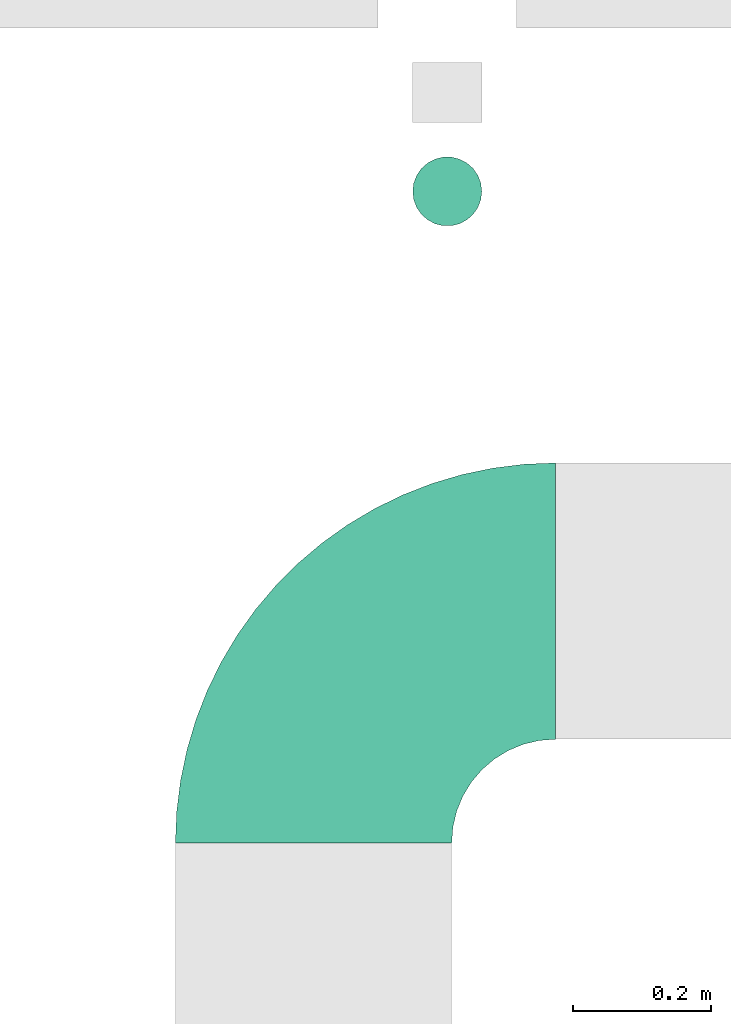
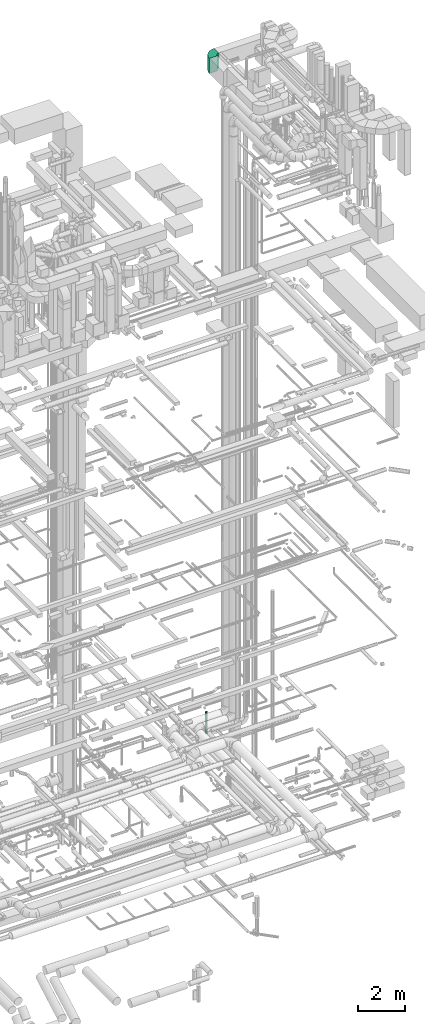
# One storey, part 80 of 337: 1 flow fitting, 1 flow segment.
"""IFC2X3 building model written with IfcOpenShell, lengths in millimetres."""

from ifc_helpers import new_model, entity, si_unit, converted_unit, derived_unit, direction, frame, frame_2d, origin, origin_2d_with_axis, place, context, subcontext, project, spatial, polyline, circle_curve, parameter, trimmed, segment, composite_curve, circle, outline, extrude, source, transform, mapped, material, type_object, type_shapes, element, save


model = new_model("IFC2X3")

# Units and contexts
model_context = context("Model", 3, precision=0.01, world=origin(), true_north=direction((6.12303176911189e-17, 1.0)))
body_context = subcontext(model_context, "Body", "Model", "MODEL_VIEW")
ifc_project = project(units=[si_unit("LENGTHUNIT", "METRE", prefix="MILLI"), si_unit("AREAUNIT", "SQUARE_METRE"), si_unit("VOLUMEUNIT", "CUBIC_METRE"), converted_unit("PLANEANGLEUNIT", "DEGREE", entity("IfcRatioMeasure", 0.0174532925199433), si_unit("PLANEANGLEUNIT", "RADIAN"), dimensions=[0, 0, 0, 0, 0, 0, 0]), si_unit("MASSUNIT", "GRAM", prefix="KILO"), derived_unit("MASSDENSITYUNIT", [(si_unit("MASSUNIT", "GRAM", prefix="KILO"), 1), (si_unit("LENGTHUNIT", "METRE"), -3)]), derived_unit("MOMENTOFINERTIAUNIT", [(si_unit("LENGTHUNIT", "METRE"), 4)]), si_unit("TIMEUNIT", "SECOND"), si_unit("FREQUENCYUNIT", "HERTZ"), si_unit("THERMODYNAMICTEMPERATUREUNIT", "DEGREE_CELSIUS"), derived_unit("THERMALTRANSMITTANCEUNIT", [(si_unit("MASSUNIT", "GRAM", prefix="KILO"), 1), (si_unit("THERMODYNAMICTEMPERATUREUNIT", "KELVIN"), -1), (si_unit("TIMEUNIT", "SECOND"), -3)]), derived_unit("VOLUMETRICFLOWRATEUNIT", [(si_unit("LENGTHUNIT", "METRE"), 3), (si_unit("TIMEUNIT", "SECOND"), -1)]), derived_unit("MASSFLOWRATEUNIT", [(si_unit("MASSUNIT", "GRAM", prefix="KILO"), 1), (si_unit("TIMEUNIT", "SECOND"), -1)]), derived_unit("ROTATIONALFREQUENCYUNIT", [(si_unit("TIMEUNIT", "SECOND"), -1)]), si_unit("ELECTRICCURRENTUNIT", "AMPERE"), si_unit("ELECTRICVOLTAGEUNIT", "VOLT"), si_unit("POWERUNIT", "WATT"), si_unit("FORCEUNIT", "NEWTON", prefix="KILO"), si_unit("ILLUMINANCEUNIT", "LUX"), si_unit("LUMINOUSFLUXUNIT", "LUMEN"), si_unit("LUMINOUSINTENSITYUNIT", "CANDELA"), derived_unit("USERDEFINED", [(si_unit("MASSUNIT", "GRAM", prefix="KILO"), -1), (si_unit("LENGTHUNIT", "METRE"), -2), (si_unit("TIMEUNIT", "SECOND"), 3), (si_unit("LUMINOUSFLUXUNIT", "LUMEN"), 1)]), derived_unit("LINEARVELOCITYUNIT", [(si_unit("LENGTHUNIT", "METRE"), 1), (si_unit("TIMEUNIT", "SECOND"), -1)]), si_unit("PRESSUREUNIT", "PASCAL"), derived_unit("USERDEFINED", [(si_unit("LENGTHUNIT", "METRE"), -2), (si_unit("MASSUNIT", "GRAM", prefix="KILO"), 1), (si_unit("TIMEUNIT", "SECOND"), -2)]), derived_unit("LINEARFORCEUNIT", [(si_unit("MASSUNIT", "GRAM", prefix="KILO"), 1), (si_unit("LENGTHUNIT", "METRE"), 1), (si_unit("TIMEUNIT", "SECOND"), -2), (si_unit("LENGTHUNIT", "METRE"), -1)]), derived_unit("PLANARFORCEUNIT", [(si_unit("MASSUNIT", "GRAM", prefix="KILO"), 1), (si_unit("LENGTHUNIT", "METRE"), 1), (si_unit("TIMEUNIT", "SECOND"), -2), (si_unit("LENGTHUNIT", "METRE"), -2)])], contexts=[model_context])

# Site, building, storey
site_placement = place(None, origin())
site = spatial("IfcSite", under=ifc_project, at=site_placement, CompositionType="ELEMENT")
building_placement = place(site_placement, origin())
building = spatial("IfcBuilding", under=site, at=building_placement, CompositionType="ELEMENT")
storey_placement = place(building_placement, origin())
storey = spatial("IfcBuildingStorey", under=building, at=storey_placement, CompositionType="ELEMENT", Elevation=0.0)

# Flow segment
duct_segment_type = type_object("IfcDuctSegmentType", PredefinedType="NOTDEFINED")
flow_segment_placement = place(storey_placement, frame((69597.36, 17685.12, -2150.0)))
element("IfcFlowSegment", 1, at=flow_segment_placement, inside=storey, type_object=duct_segment_type, context=body_context, shape_type="SweptSolid", body=[
    extrude(circle(Radius=50.0, at=origin_2d_with_axis()), frame((51.6, 51.6, 0.0), z_axis=(0.0, 0.0, 1.0), x_axis=(-1.0, 0.0, 0.0)), (0.0, 0.0, 1.0), 1150.00000000001),
])

# Flow fitting
ifc_material = material()
duct_fitting_type = type_object("IfcDuctFittingType", PredefinedType="NOTDEFINED", material=ifc_material)
shared_shape = source(origin(), body_context, "Body", "SweptSolid", [
    extrude(outline(composite_curve([segment(polyline([(-375.0, -175.0), (25.0, -175.0)]), True, "CONTINUOUS"), segment(trimmed(circle_curve(frame_2d((175.0, -175.0), x_axis=(0.0, 1.0)), 150.0), [parameter(0.0)], [parameter(90.0000000000001)], True, "PARAMETER"), False, "CONTINUOUS"), segment(polyline([(175.0, -25.0), (175.0, 375.0)]), True, "CONTINUOUS"), segment(trimmed(circle_curve(frame_2d((175.0, -175.0), x_axis=(0.0, 1.0)), 550.0), [parameter(0.0)], [parameter(90.0)], True, "PARAMETER"), True, "CONTINUOUS")], self_intersect=False)), frame((-175.0, 175.0, -400.0), z_axis=(0.0, 0.0, 1.0), x_axis=(-1.0, 0.0, 0.0)), (0.0, 0.0, 1.0), 800.0),
])
type_shapes(duct_fitting_type, [shared_shape])
flow_fitting_placement = place(storey_placement, frame((69455.37, 17143.61, 33550.0), z_axis=(0.0, 0.0, 1.0), x_axis=(-1.0, 0.0, 0.0)))
element("IfcFlowFitting", 2, at=flow_fitting_placement, inside=storey, type_object=duct_fitting_type, material=ifc_material, context=body_context, shape_type="MappedRepresentation", body=[
    mapped(shared_shape, transform((0.0, 0.0, 0.0), scale=1.0)),
])

save(model, "model.ifc")
